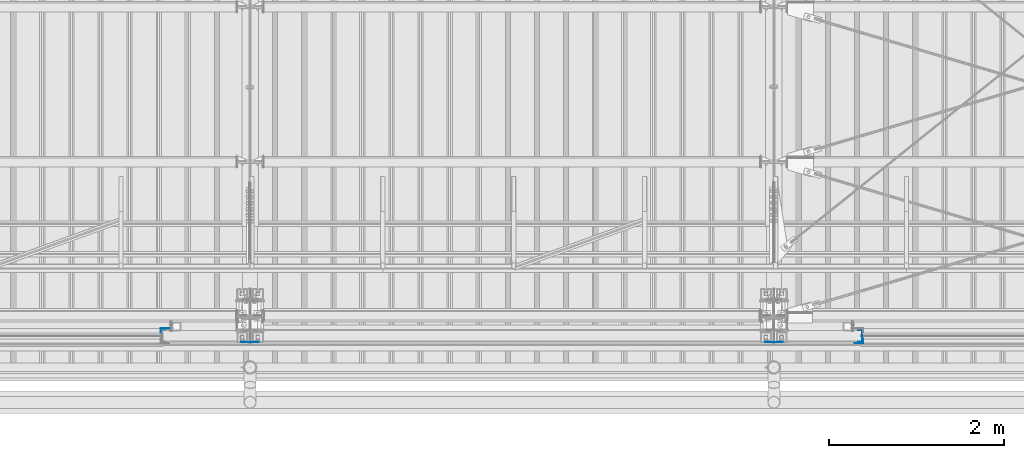
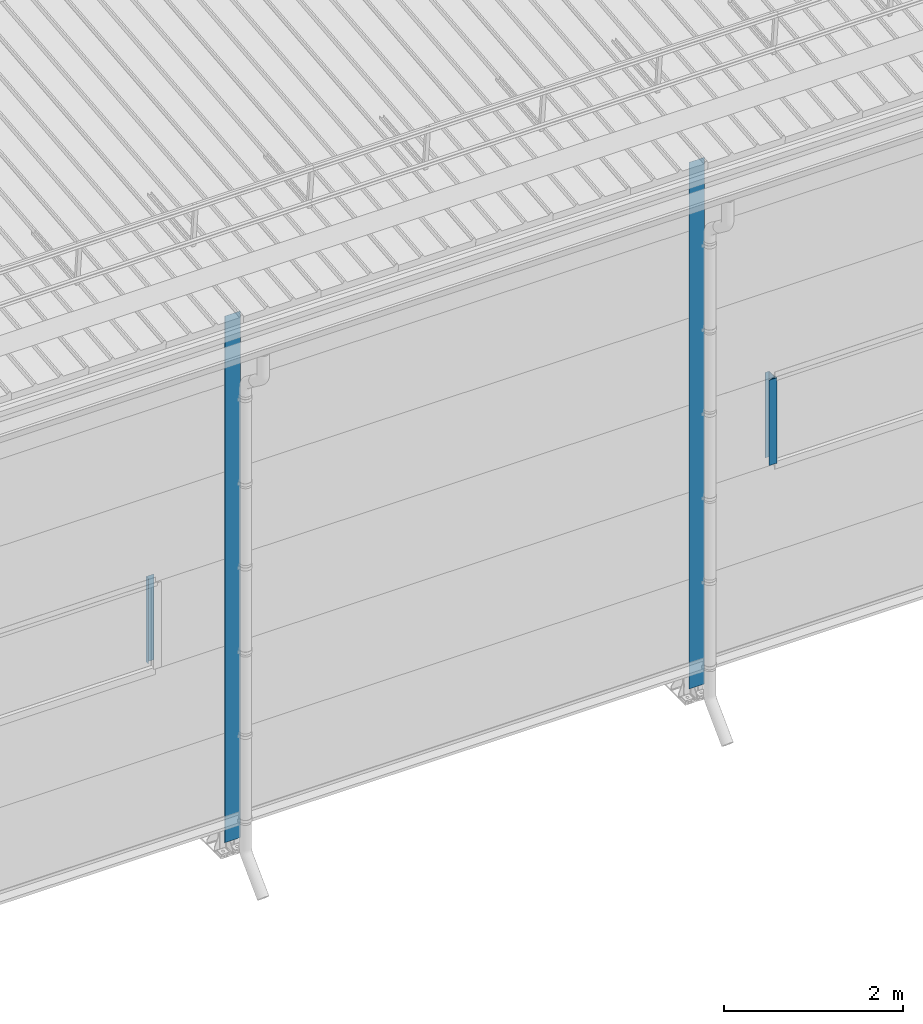
# One storey, part 11 of 709: 5 columns, 5 elements without a shape of their own.
"""IFC4 building model written with IfcOpenShell, lengths in millimetres."""

from ifc_helpers import new_model, si_unit, direction, frame, origin_with_axes, place, context, subcontext, project, spatial, line, indexed_curve, outline, extrude, material, element, aggregate, save


model = new_model("IFC4")

# Units and contexts
model_context = context("Model", 3, precision=0.2, world=origin_with_axes(), true_north=direction((0.0, 1.0)))
body_context = subcontext(model_context, "Body", "Model", "MODEL_VIEW")
ifc_project = project(units=[si_unit("LENGTHUNIT", "METRE", prefix="MILLI"), si_unit("AREAUNIT", "SQUARE_METRE"), si_unit("VOLUMEUNIT", "CUBIC_METRE"), si_unit("MASSUNIT", "GRAM", prefix="KILO"), si_unit("TIMEUNIT", "SECOND"), si_unit("PLANEANGLEUNIT", "RADIAN"), si_unit("SOLIDANGLEUNIT", "STERADIAN"), si_unit("THERMODYNAMICTEMPERATUREUNIT", "DEGREE_CELSIUS"), si_unit("LUMINOUSINTENSITYUNIT", "LUMEN")], contexts=[model_context])

# Site, building, storey
site_placement = place(None, origin_with_axes())
site = spatial("IfcSite", under=ifc_project, at=site_placement, CompositionType="ELEMENT")
building_placement = place(site_placement, origin_with_axes())
building = spatial("IfcBuilding", under=site, at=building_placement, Name="Undefined", CompositionType="ELEMENT")
storey_placement = place(building_placement, origin_with_axes())
storey = spatial("IfcBuildingStorey", under=building, at=storey_placement, Name="Undefined", CompositionType="ELEMENT", Elevation=0.0)

# Assembly, column
assembly_1_placement = place(storey_placement, frame((32975.0, 1.0, 2700.0), z_axis=(0.0, 1.0, 0.0), x_axis=(0.0, 0.0, 1.0)))
assembly_1 = element("IfcElementAssembly", 1, at=assembly_1_placement, inside=storey)
ifc_material = material(Name="Steel_Undefined", Category="STEEL")
column_1_placement = place(assembly_1_placement, origin_with_axes())
column_1 = element("IfcColumn", 2, at=column_1_placement, material=ifc_material, context=body_context, shape_type="SolidModel", body=[
    extrude(outline(indexed_curve([(-25.0, -1.0), (25.0, -1.0), (25.0, 99.0), (23.0, 99.0), (23.0, 1.0), (-25.0, 1.0)], segments=[line(1, 2, 3, 4, 5, 6, 1)])), frame((0.0, 0.0, 0.0), z_axis=(-1.0, 0.0, 0.0), x_axis=(0.0, 0.0, 1.0)), (0.0, 0.0, -1.0), 1170.0),
])
aggregate(assembly_1, [column_1])

assembly_2_placement = place(storey_placement, frame((40990.0, -60.0, 2700.0), z_axis=(0.0, 1.0, 0.0), x_axis=(0.0, 0.0, 1.0)))
assembly_2 = element("IfcElementAssembly", 3, at=assembly_2_placement, inside=storey)
column_2_placement = place(assembly_2_placement, origin_with_axes())
column_2 = element("IfcColumn", 4, at=column_2_placement, material=ifc_material, context=body_context, shape_type="SolidModel", body=[
    extrude(outline(indexed_curve([(-70.0, -25.0), (-68.0, -25.0), (-68.0, 23.0), (68.0, 23.0), (68.0, -25.0), (70.0, -25.0), (70.0, 25.0), (-70.0, 25.0)], segments=[line(1, 2, 3, 4, 5, 6, 7, 8, 1)])), frame((0.0, 0.0, 0.0), z_axis=(-1.0, 0.0, 0.0), x_axis=(0.0, 0.0, 1.0)), (0.0, 0.0, -1.0), 1170.0),
])
aggregate(assembly_2, [column_2])

assembly_3_placement = place(storey_placement, frame((41025.0, -119.0, 2700.0), z_axis=(0.0, -1.0, 0.0), x_axis=(0.0, 0.0, 1.0)))
assembly_3 = element("IfcElementAssembly", 5, at=assembly_3_placement, inside=storey)
column_3_placement = place(assembly_3_placement, origin_with_axes())
column_3 = element("IfcColumn", 6, at=column_3_placement, material=ifc_material, context=body_context, shape_type="SolidModel", body=[
    extrude(outline(indexed_curve([(-25.0, -1.0), (25.0, -1.0), (25.0, 99.0), (23.0, 99.0), (23.0, 1.0), (-25.0, 1.0)], segments=[line(1, 2, 3, 4, 5, 6, 1)])), frame((0.0, 0.0, 0.0), z_axis=(-1.0, 0.0, 0.0), x_axis=(0.0, 0.0, 1.0)), (0.0, 0.0, -1.0), 1170.0),
])
aggregate(assembly_3, [column_3])

assembly_4_placement = place(storey_placement, frame((34000.0, -130.0, 0.0), z_axis=(0.0, 1.0, 0.0), x_axis=(0.0, 0.0, 1.0)))
assembly_4 = element("IfcElementAssembly", 7, at=assembly_4_placement, inside=storey)
column_4_placement = place(assembly_4_placement, origin_with_axes())
column_4 = element("IfcColumn", 8, at=column_4_placement, material=ifc_material, context=body_context, shape_type="SolidModel", body=[
    extrude(outline(indexed_curve([(-0.375, -100.0), (1.245, -100.0), (1.245, -50.0), (0.495, -50.0), (0.495, -99.25), (0.375, -99.25), (0.375, 99.25), (0.495, 99.25), (0.495, 50.0), (1.245, 50.0), (1.245, 100.0), (-0.375, 100.0)], segments=[line(1, 2, 3, 4, 5, 6, 7, 8, 9, 10, 11, 12, 1)])), frame((0.0, 0.0, 0.0), z_axis=(-1.0, 0.0, 0.0), x_axis=(0.0, 0.0, 1.0)), (0.0, 0.0, -1.0), 7196.92297),
])
aggregate(assembly_4, [column_4])

assembly_5_placement = place(storey_placement, frame((40000.0, -130.0, 0.0), z_axis=(0.0, 1.0, 0.0), x_axis=(0.0, 0.0, 1.0)))
assembly_5 = element("IfcElementAssembly", 9, at=assembly_5_placement, inside=storey)
column_5_placement = place(assembly_5_placement, origin_with_axes())
column_5 = element("IfcColumn", 10, at=column_5_placement, material=ifc_material, context=body_context, shape_type="SolidModel", body=[
    extrude(outline(indexed_curve([(-0.375, -100.0), (1.245, -100.0), (1.245, -50.0), (0.495, -50.0), (0.495, -99.25), (0.375, -99.25), (0.375, 99.25), (0.495, 99.25), (0.495, 50.0), (1.245, 50.0), (1.245, 100.0), (-0.375, 100.0)], segments=[line(1, 2, 3, 4, 5, 6, 7, 8, 9, 10, 11, 12, 1)])), frame((0.0, 0.0, 0.0), z_axis=(-1.0, 0.0, 0.0), x_axis=(0.0, 0.0, 1.0)), (0.0, 0.0, -1.0), 7196.92297),
])
aggregate(assembly_5, [column_5])

save(model, "model.ifc")
